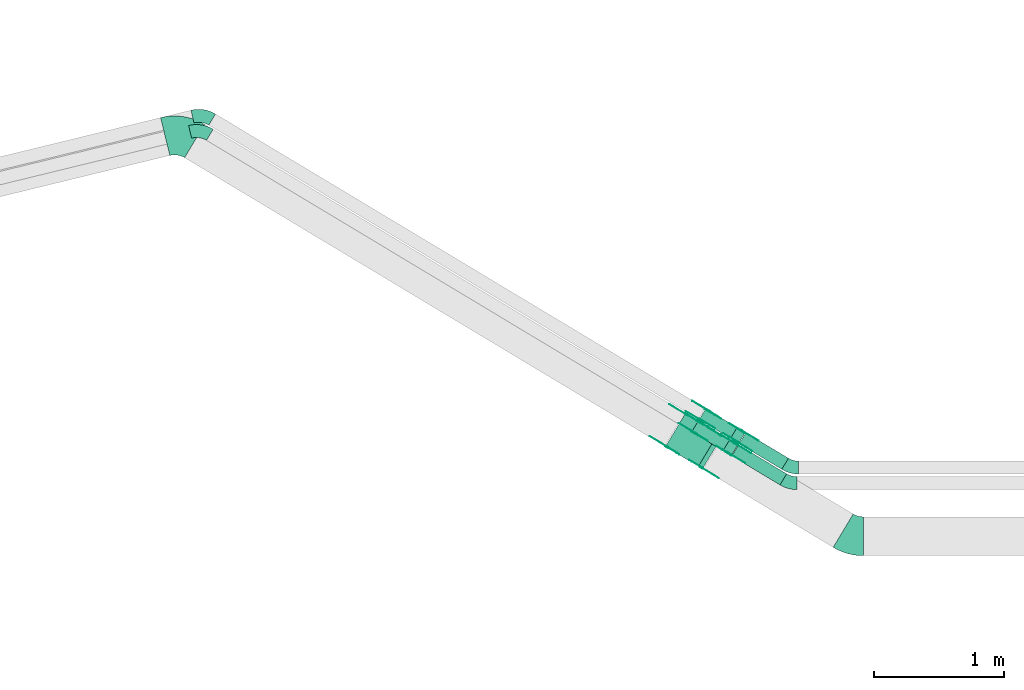
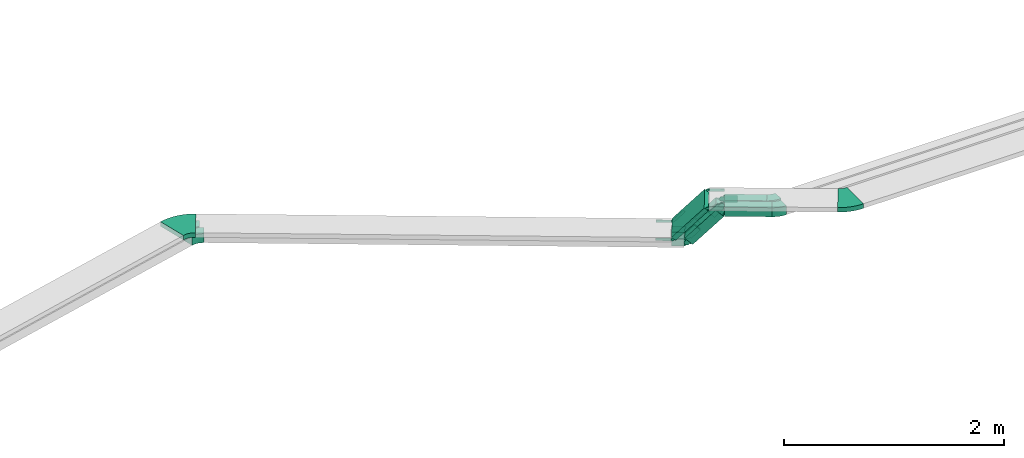
# One storey, part 4 of 27: 30 flow fittings, 5 flow segments.
"""IFC2X3 building model written with IfcOpenShell, lengths in millimetres."""

from ifc_helpers import new_model, entity, si_unit, converted_unit, derived_unit, direction, frame, frame_2d, origin, origin_2d_with_axis, place, context, subcontext, project, spatial, polyline, circle_curve, parameter, trimmed, segment, composite_curve, rectangle, outline, extrude, source, transform, mapped, material, type_object, type_shapes, element, save


model = new_model("IFC2X3")

# Units and contexts
model_context = context("Model", 3, precision=0.01, world=origin(), true_north=direction((6.12303176911189e-17, 1.0)))
body_context = subcontext(model_context, "Body", "Model", "MODEL_VIEW")
ifc_project = project(units=[si_unit("LENGTHUNIT", "METRE", prefix="MILLI"), si_unit("AREAUNIT", "SQUARE_METRE"), si_unit("VOLUMEUNIT", "CUBIC_METRE"), converted_unit("PLANEANGLEUNIT", "DEGREE", entity("IfcRatioMeasure", 0.0174532925199433), si_unit("PLANEANGLEUNIT", "RADIAN"), dimensions=[0, 0, 0, 0, 0, 0, 0]), si_unit("MASSUNIT", "GRAM", prefix="KILO"), derived_unit("MASSDENSITYUNIT", [(si_unit("MASSUNIT", "GRAM", prefix="KILO"), 1), (si_unit("LENGTHUNIT", "METRE"), -3)]), derived_unit("MOMENTOFINERTIAUNIT", [(si_unit("LENGTHUNIT", "METRE"), 4)]), si_unit("TIMEUNIT", "SECOND"), si_unit("FREQUENCYUNIT", "HERTZ"), si_unit("THERMODYNAMICTEMPERATUREUNIT", "DEGREE_CELSIUS"), derived_unit("THERMALTRANSMITTANCEUNIT", [(si_unit("MASSUNIT", "GRAM", prefix="KILO"), 1), (si_unit("THERMODYNAMICTEMPERATUREUNIT", "KELVIN"), -1), (si_unit("TIMEUNIT", "SECOND"), -3)]), derived_unit("VOLUMETRICFLOWRATEUNIT", [(si_unit("LENGTHUNIT", "METRE"), 3), (si_unit("TIMEUNIT", "SECOND"), -1)]), derived_unit("MASSFLOWRATEUNIT", [(si_unit("MASSUNIT", "GRAM", prefix="KILO"), 1), (si_unit("TIMEUNIT", "SECOND"), -1)]), derived_unit("ROTATIONALFREQUENCYUNIT", [(si_unit("TIMEUNIT", "SECOND"), -1)]), si_unit("ELECTRICCURRENTUNIT", "AMPERE"), si_unit("ELECTRICVOLTAGEUNIT", "VOLT"), si_unit("POWERUNIT", "WATT"), si_unit("FORCEUNIT", "NEWTON", prefix="KILO"), si_unit("ILLUMINANCEUNIT", "LUX"), si_unit("LUMINOUSFLUXUNIT", "LUMEN"), si_unit("LUMINOUSINTENSITYUNIT", "CANDELA"), derived_unit("USERDEFINED", [(si_unit("MASSUNIT", "GRAM", prefix="KILO"), -1), (si_unit("LENGTHUNIT", "METRE"), -2), (si_unit("TIMEUNIT", "SECOND"), 3), (si_unit("LUMINOUSFLUXUNIT", "LUMEN"), 1)]), derived_unit("LINEARVELOCITYUNIT", [(si_unit("LENGTHUNIT", "METRE"), 1), (si_unit("TIMEUNIT", "SECOND"), -1)]), si_unit("PRESSUREUNIT", "PASCAL"), derived_unit("USERDEFINED", [(si_unit("LENGTHUNIT", "METRE"), -2), (si_unit("MASSUNIT", "GRAM", prefix="KILO"), 1), (si_unit("TIMEUNIT", "SECOND"), -2)]), derived_unit("LINEARFORCEUNIT", [(si_unit("MASSUNIT", "GRAM", prefix="KILO"), 1), (si_unit("LENGTHUNIT", "METRE"), 1), (si_unit("TIMEUNIT", "SECOND"), -2), (si_unit("LENGTHUNIT", "METRE"), -1)]), derived_unit("PLANARFORCEUNIT", [(si_unit("MASSUNIT", "GRAM", prefix="KILO"), 1), (si_unit("LENGTHUNIT", "METRE"), 1), (si_unit("TIMEUNIT", "SECOND"), -2), (si_unit("LENGTHUNIT", "METRE"), -2)])], contexts=[model_context])

# Site, building, storey
site_placement = place(None, origin())
site = spatial("IfcSite", under=ifc_project, at=site_placement, CompositionType="ELEMENT")
building_placement = place(site_placement, origin())
building = spatial("IfcBuilding", under=site, at=building_placement, CompositionType="ELEMENT")
storey_placement = place(building_placement, origin())
storey = spatial("IfcBuildingStorey", under=building, at=storey_placement, CompositionType="ELEMENT", Elevation=0.0)

# Flow segments
cable_carrier_segment_type = type_object("IfcCableCarrierSegmentType", PredefinedType="CABLETRAYSEGMENT")
flow_segment_1_placement = place(storey_placement, frame((2555.69, 12171.22, 2950.0)))
element("IfcFlowSegment", 1, at=flow_segment_1_placement, inside=storey, type_object=cable_carrier_segment_type, context=body_context, shape_type="SweptSolid", body=[
    extrude(rectangle(XDim=432.962240895032, YDim=99.9999999999993, at=origin_2d_with_axis()), frame((211.31, 154.35, 0.0), z_axis=(0.0, 0.0, 1.0), x_axis=(-0.857167300702077, 0.515038074910114, 0.0)), (0.0, 0.0, 1.0), 99.9999999999994),
])
flow_segment_2_placement = place(storey_placement, frame((2612.35, 12291.22, 2950.0)))
element("IfcFlowSegment", 2, at=flow_segment_2_placement, inside=storey, type_object=cable_carrier_segment_type, context=body_context, shape_type="SweptSolid", body=[
    extrude(rectangle(XDim=383.040500784393, YDim=99.9999999999987, at=origin_2d_with_axis()), frame((189.92, 141.5, 0.0), z_axis=(0.0, 0.0, 1.0), x_axis=(-0.85716730070208, 0.515038074910108, 0.0)), (0.0, 0.0, 1.0), 100.0),
])
flow_segment_3_placement = place(storey_placement, frame((2246.61, 12396.61, 2635.15)))
element("IfcFlowSegment", 3, at=flow_segment_3_placement, inside=storey, type_object=cable_carrier_segment_type, context=body_context, shape_type="SweptSolid", body=[
    extrude(rectangle(XDim=100.000000000001, YDim=99.9999999999976, at=frame_2d((0.0, 0.0), x_axis=(0.0, 1.0))), frame((57.6, 207.05, 33.46), z_axis=(0.57355687566977, -0.344627739362477, 0.743144825477403), x_axis=(-0.515038074910093, -0.857167300702089, 0.0)), (0.0, 0.0, 1.0), 420.88675734891),
])
flow_segment_4_placement = place(storey_placement, frame((2043.9, 12294.88, 2818.61)))
element("IfcFlowSegment", 4, at=flow_segment_4_placement, inside=storey, type_object=cable_carrier_segment_type, context=body_context, shape_type="SweptSolid", body=[
    extrude(rectangle(XDim=50.0000000000007, YDim=300.0, at=frame_2d((0.0, 0.0), x_axis=(0.0, 1.0))), frame((93.18, 290.86, 16.73), z_axis=(0.573556875669757, -0.344627739362442, 0.74314482547743), x_axis=(0.515038074910054, 0.857167300702113, 0.0)), (0.0, 0.0, 1.0), 443.148191614342),
])
flow_segment_5_placement = place(storey_placement, frame((2303.27, 12490.89, 2635.15)))
element("IfcFlowSegment", 5, at=flow_segment_5_placement, inside=storey, type_object=cable_carrier_segment_type, context=body_context, shape_type="SweptSolid", body=[
    extrude(rectangle(XDim=100.0, YDim=99.999999999998, at=frame_2d((0.0, 0.0), x_axis=(0.0, 1.0))), frame((57.6, 207.05, 33.46), z_axis=(0.573556875672807, -0.344627739364302, 0.743144825474213), x_axis=(-0.515038074910098, -0.857167300702086, 0.0)), (0.0, 0.0, 1.0), 420.886757348871),
])

# Flow fittings
ifc_material_1 = material(Name="G")
cable_carrier_fitting_type_1 = type_object("IfcCableCarrierFittingType", PredefinedType="NOTDEFINED", material=ifc_material_1)
shared_shape_1 = source(origin(), body_context, "Body", "SweptSolid", [
    extrude(outline(composite_curve([segment(trimmed(circle_curve(frame_2d((-44.59, 0.0), x_axis=(1.0, 0.0)), 12.5), [parameter(90.0000000000007)], [parameter(270.0)], True, "PARAMETER"), True, "CONTINUOUS"), segment(polyline([(-44.59, -12.5), (-33.09, -12.5)]), True, "CONTINUOUS"), segment(polyline([(-33.09, -12.5), (-31.23, -14.5)]), True, "CONTINUOUS"), segment(polyline([(-31.23, -14.5), (108.91, -14.5)]), True, "CONTINUOUS"), segment(polyline([(108.91, -14.5), (108.91, 14.5)]), True, "CONTINUOUS"), segment(polyline([(108.91, 14.5), (-31.23, 14.5)]), True, "CONTINUOUS"), segment(polyline([(-31.23, 14.5), (-33.09, 12.5)]), True, "CONTINUOUS"), segment(polyline([(-33.09, 12.5), (-44.59, 12.5)]), True, "CONTINUOUS")], self_intersect=False)), frame((44.59, 0.0, 0.0), z_axis=(0.0, 0.0, -1.0), x_axis=(1.0, 0.0, 0.0)), (0.0, 0.0, -1.0), 2.0),
])
type_shapes(cable_carrier_fitting_type_1, [shared_shape_1])
flow_fitting_1_placement = place(storey_placement, frame((2054.18, 12465.85, 2825.0), z_axis=(-0.515038074910058, -0.85716730070211, 0.0), x_axis=(0.57355687566975, -0.344627739362441, 0.743144825477436)))
element("IfcFlowFitting", 6, at=flow_fitting_1_placement, inside=storey, type_object=cable_carrier_fitting_type_1, material=ifc_material_1, context=body_context, shape_type="MappedRepresentation", body=[
    mapped(shared_shape_1, transform((0.0, 0.0, 0.0), scale=1.0)),
])
cable_carrier_fitting_type_2 = type_object("IfcCableCarrierFittingType", PredefinedType="NOTDEFINED", material=ifc_material_1)
type_shapes(cable_carrier_fitting_type_2, [shared_shape_1])
flow_fitting_2_placement = place(storey_placement, frame((2202.99, 12713.51, 2825.0), z_axis=(0.515038074910046, 0.857167300702117, 0.0), x_axis=(-0.857167300702117, 0.515038074910046, 0.0)))
element("IfcFlowFitting", 7, at=flow_fitting_2_placement, inside=storey, type_object=cable_carrier_fitting_type_2, material=ifc_material_1, context=body_context, shape_type="MappedRepresentation", body=[
    mapped(shared_shape_1, transform((0.0, 0.0, 0.0), scale=1.0)),
])
flow_fitting_3_placement = place(storey_placement, frame((2474.15, 12552.91, 3175.0), z_axis=(0.515038074910075, 0.8571673007021, 0.0), x_axis=(0.8571673007021, -0.515038074910075, 0.0)))
element("IfcFlowFitting", 8, at=flow_fitting_3_placement, inside=storey, type_object=cable_carrier_fitting_type_1, material=ifc_material_1, context=body_context, shape_type="MappedRepresentation", body=[
    mapped(shared_shape_1, transform((0.0, 0.0, 0.0), scale=1.0)),
])
flow_fitting_4_placement = place(storey_placement, frame((2325.34, 12305.26, 3175.0), z_axis=(-0.515038074910083, -0.857167300702095, 0.0), x_axis=(-0.57355687566976, 0.344627739362467, -0.743144825477416)))
element("IfcFlowFitting", 9, at=flow_fitting_4_placement, inside=storey, type_object=cable_carrier_fitting_type_2, material=ifc_material_1, context=body_context, shape_type="MappedRepresentation", body=[
    mapped(shared_shape_1, transform((0.0, 0.0, 0.0), scale=1.0)),
])
cable_carrier_fitting_type_3 = type_object("IfcCableCarrierFittingType", PredefinedType="NOTDEFINED", material=ifc_material_1)
shared_shape_2 = source(origin(), body_context, "Body", "SweptSolid", [
    extrude(outline(composite_curve([segment(trimmed(circle_curve(frame_2d((-44.59, 0.0), x_axis=(1.0, 0.0)), 12.5), [parameter(90.0000000000007)], [parameter(270.0)], True, "PARAMETER"), True, "CONTINUOUS"), segment(polyline([(-44.59, -12.5), (-33.09, -12.5)]), True, "CONTINUOUS"), segment(polyline([(-33.09, -12.5), (-31.23, -14.5)]), True, "CONTINUOUS"), segment(polyline([(-31.23, -14.5), (108.91, -14.5)]), True, "CONTINUOUS"), segment(polyline([(108.91, -14.5), (108.91, 14.5)]), True, "CONTINUOUS"), segment(polyline([(108.91, 14.5), (-31.23, 14.5)]), True, "CONTINUOUS"), segment(polyline([(-31.23, 14.5), (-33.09, 12.5)]), True, "CONTINUOUS"), segment(polyline([(-33.09, 12.5), (-44.59, 12.5)]), True, "CONTINUOUS")], self_intersect=False)), frame((44.59, 0.0, 0.0)), (0.0, 0.0, 1.0), 2.0),
])
type_shapes(cable_carrier_fitting_type_3, [shared_shape_2])
flow_fitting_5_placement = place(storey_placement, frame((2204.02, 12715.22, 2825.0), z_axis=(0.515038074910066, 0.857167300702105, 0.0), x_axis=(0.573556875669743, -0.344627739362453, 0.743144825477436)))
element("IfcFlowFitting", 10, at=flow_fitting_5_placement, inside=storey, type_object=cable_carrier_fitting_type_3, material=ifc_material_1, context=body_context, shape_type="MappedRepresentation", body=[
    mapped(shared_shape_2, transform((0.0, 0.0, 0.0), scale=1.0)),
])
cable_carrier_fitting_type_4 = type_object("IfcCableCarrierFittingType", PredefinedType="NOTDEFINED", material=ifc_material_1)
type_shapes(cable_carrier_fitting_type_4, [shared_shape_2])
flow_fitting_6_placement = place(storey_placement, frame((2055.21, 12467.57, 2825.0), z_axis=(-0.51503807491007, -0.857167300702103, 0.0), x_axis=(-0.857167300702103, 0.51503807491007, 0.0)))
element("IfcFlowFitting", 11, at=flow_fitting_6_placement, inside=storey, type_object=cable_carrier_fitting_type_4, material=ifc_material_1, context=body_context, shape_type="MappedRepresentation", body=[
    mapped(shared_shape_2, transform((0.0, 0.0, 0.0), scale=1.0)),
])
flow_fitting_7_placement = place(storey_placement, frame((2324.31, 12303.54, 3175.0), z_axis=(-0.515038074910064, -0.857167300702107, 0.0), x_axis=(0.857167300702107, -0.515038074910064, 0.0)))
element("IfcFlowFitting", 12, at=flow_fitting_7_placement, inside=storey, type_object=cable_carrier_fitting_type_3, material=ifc_material_1, context=body_context, shape_type="MappedRepresentation", body=[
    mapped(shared_shape_2, transform((0.0, 0.0, 0.0), scale=1.0)),
])
flow_fitting_8_placement = place(storey_placement, frame((2473.12, 12551.2, 3175.0), z_axis=(0.515038074910059, 0.85716730070211, 0.0), x_axis=(-0.573556875669774, 0.344627739362443, -0.743144825477416)))
element("IfcFlowFitting", 13, at=flow_fitting_8_placement, inside=storey, type_object=cable_carrier_fitting_type_4, material=ifc_material_1, context=body_context, shape_type="MappedRepresentation", body=[
    mapped(shared_shape_2, transform((0.0, 0.0, 0.0), scale=1.0)),
])
cable_carrier_fitting_type_5 = type_object("IfcCableCarrierFittingType", PredefinedType="NOTDEFINED", material=ifc_material_1)
shared_shape_3 = source(origin(), body_context, "Body", "SweptSolid", [
    extrude(outline(composite_curve([segment(trimmed(circle_curve(frame_2d((-41.47, 0.0), x_axis=(1.0, 0.0)), 25.0), [parameter(90.0000000000007)], [parameter(270.0)], True, "PARAMETER"), True, "CONTINUOUS"), segment(polyline([(-41.47, -25.0), (-29.97, -25.0)]), True, "CONTINUOUS"), segment(polyline([(-29.97, -25.0), (-28.1, -38.5)]), True, "CONTINUOUS"), segment(polyline([(-28.1, -38.5), (99.53, -38.5)]), True, "CONTINUOUS"), segment(polyline([(99.53, -38.5), (99.53, 38.5)]), True, "CONTINUOUS"), segment(polyline([(99.53, 38.5), (-28.1, 38.5)]), True, "CONTINUOUS"), segment(polyline([(-28.1, 38.5), (-29.97, 25.0)]), True, "CONTINUOUS"), segment(polyline([(-29.97, 25.0), (-41.47, 25.0)]), True, "CONTINUOUS")], self_intersect=False)), frame((41.47, 0.0, 0.0), z_axis=(0.0, 0.0, -1.0), x_axis=(1.0, 0.0, 0.0)), (0.0, 0.0, -1.0), 2.0),
])
type_shapes(cable_carrier_fitting_type_5, [shared_shape_3])
flow_fitting_9_placement = place(storey_placement, frame((2536.57, 12411.0, 3000.0), z_axis=(-0.515038074910089, -0.857167300702091, 0.0), x_axis=(-0.573556875669768, 0.344627739362478, -0.743144825477405)))
element("IfcFlowFitting", 14, at=flow_fitting_9_placement, inside=storey, type_object=cable_carrier_fitting_type_5, material=ifc_material_1, context=body_context, shape_type="MappedRepresentation", body=[
    mapped(shared_shape_3, transform((0.0, 0.0, 0.0), scale=1.0)),
])
cable_carrier_fitting_type_6 = type_object("IfcCableCarrierFittingType", PredefinedType="NOTDEFINED", material=ifc_material_1)
type_shapes(cable_carrier_fitting_type_6, [shared_shape_3])
flow_fitting_10_placement = place(storey_placement, frame((2582.36, 12487.22, 3000.0), z_axis=(0.5150380749101, 0.857167300702084, 0.0), x_axis=(0.857167300702084, -0.5150380749101, 0.0)))
element("IfcFlowFitting", 15, at=flow_fitting_10_placement, inside=storey, type_object=cable_carrier_fitting_type_6, material=ifc_material_1, context=body_context, shape_type="MappedRepresentation", body=[
    mapped(shared_shape_3, transform((0.0, 0.0, 0.0), scale=1.0)),
])
flow_fitting_11_placement = place(storey_placement, frame((2266.44, 12573.31, 2650.0), z_axis=(-0.515038074910057, -0.857167300702111, 0.0), x_axis=(0.57355687566977, -0.344627739362475, 0.743144825477405)))
element("IfcFlowFitting", 16, at=flow_fitting_11_placement, inside=storey, type_object=cable_carrier_fitting_type_5, material=ifc_material_1, context=body_context, shape_type="MappedRepresentation", body=[
    mapped(shared_shape_3, transform((0.0, 0.0, 0.0), scale=1.0)),
])
flow_fitting_12_placement = place(storey_placement, frame((2312.24, 12649.53, 2650.0), z_axis=(0.515038074910046, 0.857167300702118, 0.0), x_axis=(-0.857167300702118, 0.515038074910046, 0.0)))
element("IfcFlowFitting", 17, at=flow_fitting_12_placement, inside=storey, type_object=cable_carrier_fitting_type_6, material=ifc_material_1, context=body_context, shape_type="MappedRepresentation", body=[
    mapped(shared_shape_3, transform((0.0, 0.0, 0.0), scale=1.0)),
])
flow_fitting_13_placement = place(storey_placement, frame((2640.05, 12583.23, 3000.0), z_axis=(0.5150380749101, 0.857167300702085, 0.0), x_axis=(0.857167300702085, -0.5150380749101, 0.0)))
element("IfcFlowFitting", 18, at=flow_fitting_13_placement, inside=storey, type_object=cable_carrier_fitting_type_5, material=ifc_material_1, context=body_context, shape_type="MappedRepresentation", body=[
    mapped(shared_shape_3, transform((0.0, 0.0, 0.0), scale=1.0)),
])
flow_fitting_14_placement = place(storey_placement, frame((2594.25, 12507.01, 3000.0), z_axis=(-0.515038074910108, -0.85716730070208, 0.0), x_axis=(-0.573556875669665, 0.344627739362432, -0.743144825477505)))
element("IfcFlowFitting", 19, at=flow_fitting_14_placement, inside=storey, type_object=cable_carrier_fitting_type_6, material=ifc_material_1, context=body_context, shape_type="MappedRepresentation", body=[
    mapped(shared_shape_3, transform((0.0, 0.0, 0.0), scale=1.0)),
])
flow_fitting_15_placement = place(storey_placement, frame((2369.92, 12745.54, 2650.0), z_axis=(0.515038074910055, 0.857167300702112, 0.0), x_axis=(-0.857167300702112, 0.515038074910055, 0.0)))
element("IfcFlowFitting", 20, at=flow_fitting_15_placement, inside=storey, type_object=cable_carrier_fitting_type_5, material=ifc_material_1, context=body_context, shape_type="MappedRepresentation", body=[
    mapped(shared_shape_3, transform((0.0, 0.0, 0.0), scale=1.0)),
])
flow_fitting_16_placement = place(storey_placement, frame((2324.12, 12669.32, 2650.0), z_axis=(-0.515038074910047, -0.857167300702117, 0.0), x_axis=(0.573556875669679, -0.344627739362409, 0.743144825477505)))
element("IfcFlowFitting", 21, at=flow_fitting_16_placement, inside=storey, type_object=cable_carrier_fitting_type_6, material=ifc_material_1, context=body_context, shape_type="MappedRepresentation", body=[
    mapped(shared_shape_3, transform((0.0, 0.0, 0.0), scale=1.0)),
])
cable_carrier_fitting_type_7 = type_object("IfcCableCarrierFittingType", PredefinedType="NOTDEFINED", material=ifc_material_1)
shared_shape_4 = source(origin(), body_context, "Body", "SweptSolid", [
    extrude(outline(composite_curve([segment(trimmed(circle_curve(frame_2d((-41.47, 0.0), x_axis=(1.0, 0.0)), 25.0), [parameter(90.0000000000007)], [parameter(270.0)], True, "PARAMETER"), True, "CONTINUOUS"), segment(polyline([(-41.47, -25.0), (-29.97, -25.0)]), True, "CONTINUOUS"), segment(polyline([(-29.97, -25.0), (-28.1, -38.5)]), True, "CONTINUOUS"), segment(polyline([(-28.1, -38.5), (99.53, -38.5)]), True, "CONTINUOUS"), segment(polyline([(99.53, -38.5), (99.53, 38.5)]), True, "CONTINUOUS"), segment(polyline([(99.53, 38.5), (-28.1, 38.5)]), True, "CONTINUOUS"), segment(polyline([(-28.1, 38.5), (-29.97, 25.0)]), True, "CONTINUOUS"), segment(polyline([(-29.97, 25.0), (-41.47, 25.0)]), True, "CONTINUOUS")], self_intersect=False)), frame((41.47, 0.0, 0.0)), (0.0, 0.0, 1.0), 2.0),
])
type_shapes(cable_carrier_fitting_type_7, [shared_shape_4])
flow_fitting_17_placement = place(storey_placement, frame((2583.39, 12488.94, 3000.0), z_axis=(0.515038074910081, 0.857167300702096, 0.0), x_axis=(-0.573556875669775, 0.344627739362466, -0.743144825477405)))
element("IfcFlowFitting", 22, at=flow_fitting_17_placement, inside=storey, type_object=cable_carrier_fitting_type_7, material=ifc_material_1, context=body_context, shape_type="MappedRepresentation", body=[
    mapped(shared_shape_4, transform((0.0, 0.0, 0.0), scale=1.0)),
])
cable_carrier_fitting_type_8 = type_object("IfcCableCarrierFittingType", PredefinedType="NOTDEFINED", material=ifc_material_1)
type_shapes(cable_carrier_fitting_type_8, [shared_shape_4])
flow_fitting_18_placement = place(storey_placement, frame((2537.6, 12412.72, 3000.0), z_axis=(-0.515038074910077, -0.857167300702098, 0.0), x_axis=(0.857167300702098, -0.515038074910077, 0.0)))
element("IfcFlowFitting", 23, at=flow_fitting_18_placement, inside=storey, type_object=cable_carrier_fitting_type_8, material=ifc_material_1, context=body_context, shape_type="MappedRepresentation", body=[
    mapped(shared_shape_4, transform((0.0, 0.0, 0.0), scale=1.0)),
])
flow_fitting_19_placement = place(storey_placement, frame((2313.27, 12651.25, 2650.0), z_axis=(0.515038074910065, 0.857167300702106, 0.0), x_axis=(0.573556875669763, -0.344627739362486, 0.743144825477405)))
element("IfcFlowFitting", 24, at=flow_fitting_19_placement, inside=storey, type_object=cable_carrier_fitting_type_7, material=ifc_material_1, context=body_context, shape_type="MappedRepresentation", body=[
    mapped(shared_shape_4, transform((0.0, 0.0, 0.0), scale=1.0)),
])
flow_fitting_20_placement = place(storey_placement, frame((2267.47, 12575.03, 2650.0), z_axis=(-0.515038074910069, -0.857167300702104, 0.0), x_axis=(-0.857167300702104, 0.515038074910069, 0.0)))
element("IfcFlowFitting", 25, at=flow_fitting_20_placement, inside=storey, type_object=cable_carrier_fitting_type_8, material=ifc_material_1, context=body_context, shape_type="MappedRepresentation", body=[
    mapped(shared_shape_4, transform((0.0, 0.0, 0.0), scale=1.0)),
])
flow_fitting_21_placement = place(storey_placement, frame((2593.22, 12505.29, 3000.0), z_axis=(-0.515038074910088, -0.857167300702092, 0.0), x_axis=(0.857167300702092, -0.515038074910088, 0.0)))
element("IfcFlowFitting", 26, at=flow_fitting_21_placement, inside=storey, type_object=cable_carrier_fitting_type_7, material=ifc_material_1, context=body_context, shape_type="MappedRepresentation", body=[
    mapped(shared_shape_4, transform((0.0, 0.0, 0.0), scale=1.0)),
])
flow_fitting_22_placement = place(storey_placement, frame((2639.02, 12581.51, 3000.0), z_axis=(0.515038074910083, 0.857167300702095, 0.0), x_axis=(-0.573556875669679, 0.344627739362409, -0.743144825477505)))
element("IfcFlowFitting", 27, at=flow_fitting_22_placement, inside=storey, type_object=cable_carrier_fitting_type_8, material=ifc_material_1, context=body_context, shape_type="MappedRepresentation", body=[
    mapped(shared_shape_4, transform((0.0, 0.0, 0.0), scale=1.0)),
])
flow_fitting_23_placement = place(storey_placement, frame((2323.09, 12667.6, 2650.0), z_axis=(-0.515038074910067, -0.857167300702105, 0.0), x_axis=(-0.857167300702105, 0.515038074910067, 0.0)))
element("IfcFlowFitting", 28, at=flow_fitting_23_placement, inside=storey, type_object=cable_carrier_fitting_type_7, material=ifc_material_1, context=body_context, shape_type="MappedRepresentation", body=[
    mapped(shared_shape_4, transform((0.0, 0.0, 0.0), scale=1.0)),
])
flow_fitting_24_placement = place(storey_placement, frame((2368.89, 12743.82, 2650.0), z_axis=(0.515038074910072, 0.857167300702102, 0.0), x_axis=(0.573556875669665, -0.344627739362432, 0.743144825477505)))
element("IfcFlowFitting", 29, at=flow_fitting_24_placement, inside=storey, type_object=cable_carrier_fitting_type_8, material=ifc_material_1, context=body_context, shape_type="MappedRepresentation", body=[
    mapped(shared_shape_4, transform((0.0, 0.0, 0.0), scale=1.0)),
])
ifc_material_2 = material()
cable_carrier_fitting_type_9 = type_object("IfcCableCarrierFittingType", Name="470_DKC_S5_Variable Angle Elbow 0-45:-", PredefinedType="NOTDEFINED", material=ifc_material_2)
shared_shape_5 = source(origin(), body_context, "Body", "SweptSolid", [
    extrude(outline(composite_curve([segment(polyline([(-52.47, -64.41), (-51.47, -64.41)]), True, "CONTINUOUS"), segment(trimmed(circle_curve(frame_2d((-51.47, 185.59), x_axis=(0.0, -1.0)), 250.0), [parameter(0.0)], [parameter(31.0000000000001)], True, "PARAMETER"), True, "CONTINUOUS"), segment(polyline([(77.29, -28.7), (78.15, -28.19)]), True, "CONTINUOUS"), segment(polyline([(78.15, -28.19), (26.64, 57.53)]), True, "CONTINUOUS"), segment(polyline([(26.64, 57.53), (25.79, 57.01)]), True, "CONTINUOUS"), segment(trimmed(circle_curve(frame_2d((-51.47, 185.59), x_axis=(0.0, -1.0)), 150.0), [parameter(0.0)], [parameter(31.0000000000001)], True, "PARAMETER"), False, "CONTINUOUS"), segment(polyline([(-51.47, 35.59), (-52.47, 35.59)]), True, "CONTINUOUS"), segment(polyline([(-52.47, 35.59), (-52.47, -64.41)]), True, "CONTINUOUS")], self_intersect=False)), frame((-4.0, 14.41, -50.0)), (0.0, 0.0, 1.0), 100.0),
])
type_shapes(cable_carrier_fitting_type_9, [shared_shape_5])
for number, where, z_axis, x_axis, name in (
    (30, (3000.97, 12185.0, 3000.0), (0.0, 0.0, 1.0), (0.85716730070211, -0.515038074910058, 0.0), "470_DKC_S5_Variable Angle Elbow 0-45:-"),
    (31, (3014.83, 12305.0, 3000.0), (0.0, 0.0, 1.0), (0.857167300702094, -0.515038074910084, 0.0), "470_DKC_S5_Variable Angle Elbow 0-45:-"),
):
    element("IfcFlowFitting", number, at=place(storey_placement, frame(where, z_axis=z_axis, x_axis=x_axis)), inside=storey, type_object=cable_carrier_fitting_type_9, material=ifc_material_2, Name=name, ObjectType="470_DKC_S5_Variable Angle Elbow 0-45:-", context=body_context, shape_type="MappedRepresentation", body=[
        mapped(shared_shape_5, transform((0.0, 0.0, 0.0), scale=1.0)),
    ])
cable_carrier_fitting_type_10 = type_object("IfcCableCarrierFittingType", Name="470_DKC_S5_Variable Angle Elbow 0-45:-", PredefinedType="NOTDEFINED", material=ifc_material_2)
shared_shape_6 = source(origin(), body_context, "Body", "SweptSolid", [
    extrude(outline(composite_curve([segment(polyline([(-71.27, -79.09), (-70.27, -79.09)]), True, "CONTINUOUS"), segment(trimmed(circle_curve(frame_2d((-70.27, 170.91), x_axis=(0.0, -1.0)), 250.0), [parameter(0.0)], [parameter(44.6989733065183)], True, "PARAMETER"), True, "CONTINUOUS"), segment(polyline([(105.58, -6.8), (106.29, -6.09)]), True, "CONTINUOUS"), segment(polyline([(106.29, -6.09), (35.95, 64.99)]), True, "CONTINUOUS"), segment(polyline([(35.95, 64.99), (35.24, 64.28)]), True, "CONTINUOUS"), segment(trimmed(circle_curve(frame_2d((-70.27, 170.91), x_axis=(0.0, -1.0)), 150.0), [parameter(0.0)], [parameter(44.6989733065183)], True, "PARAMETER"), False, "CONTINUOUS"), segment(polyline([(-70.27, 20.91), (-71.27, 20.91)]), True, "CONTINUOUS"), segment(polyline([(-71.27, 20.91), (-71.27, -79.09)]), True, "CONTINUOUS")], self_intersect=False)), frame((-11.96, 29.09, -50.0)), (0.0, 0.0, 1.0), 100.0),
])
type_shapes(cable_carrier_fitting_type_10, [shared_shape_6])
for number, where, z_axis, x_axis, name in (
    (32, (-1539.65, 14913.28, 2650.0), (0.0, 0.0, 1.0), (-0.857167300702109, 0.51503807491006, 0.0), "470_DKC_S5_Variable Angle Elbow 0-45:-"),
    (33, (-1521.76, 15030.86, 2650.0), (0.0, 0.0, 1.0), (-0.857167300702113, 0.515038074910054, 0.0), "470_DKC_S5_Variable Angle Elbow 0-45:-"),
):
    element("IfcFlowFitting", number, at=place(storey_placement, frame(where, z_axis=z_axis, x_axis=x_axis)), inside=storey, type_object=cable_carrier_fitting_type_10, material=ifc_material_2, Name=name, ObjectType="470_DKC_S5_Variable Angle Elbow 0-45:-", context=body_context, shape_type="MappedRepresentation", body=[
        mapped(shared_shape_6, transform((0.0, 0.0, 0.0), scale=1.0)),
    ])
cable_carrier_fitting_type_11 = type_object("IfcCableCarrierFittingType", Name="470_DKC_S5_Variable Angle Elbow 0-45:-", PredefinedType="NOTDEFINED", material=ifc_material_2)
shared_shape_7 = source(origin(), body_context, "Body", "SweptSolid", [
    extrude(outline(composite_curve([segment(polyline([(-78.22, -171.55), (-77.22, -171.55)]), True, "CONTINUOUS"), segment(trimmed(circle_curve(frame_2d((-77.22, 278.45), x_axis=(0.0, -1.0)), 450.0), [parameter(0.0)], [parameter(31.0000000000002)], True, "PARAMETER"), True, "CONTINUOUS"), segment(polyline([(154.55, -107.28), (155.4, -106.76)]), True, "CONTINUOUS"), segment(polyline([(155.4, -106.76), (0.89, 150.39)]), True, "CONTINUOUS"), segment(polyline([(0.89, 150.39), (0.04, 149.87)]), True, "CONTINUOUS"), segment(trimmed(circle_curve(frame_2d((-77.22, 278.45), x_axis=(0.0, -1.0)), 150.0), [parameter(0.0)], [parameter(31.0000000000002)], True, "PARAMETER"), False, "CONTINUOUS"), segment(polyline([(-77.22, 128.45), (-78.22, 128.45)]), True, "CONTINUOUS"), segment(polyline([(-78.22, 128.45), (-78.22, -171.55)]), True, "CONTINUOUS")], self_intersect=False)), frame((-5.98, 21.55, -25.0)), (0.0, 0.0, 1.0), 49.9999999999988),
])
type_shapes(cable_carrier_fitting_type_11, [shared_shape_7])
flow_fitting_25_placement = place(storey_placement, frame((3485.93, 11775.27, 3175.0), z_axis=(0.0, 0.0, 1.0), x_axis=(0.857167300702103, -0.515038074910069, 0.0)))
element("IfcFlowFitting", 34, at=flow_fitting_25_placement, inside=storey, type_object=cable_carrier_fitting_type_11, material=ifc_material_2, Name="470_DKC_S5_Variable Angle Elbow 0-45:-", ObjectType="470_DKC_S5_Variable Angle Elbow 0-45:-", context=body_context, shape_type="MappedRepresentation", body=[
    mapped(shared_shape_7, transform((0.0, 0.0, 0.0), scale=1.0)),
])
cable_carrier_fitting_type_12 = type_object("IfcCableCarrierFittingType", Name="470_DKC_S5_Variable Angle Elbow 0-45:-", PredefinedType="NOTDEFINED", material=ifc_material_2)
shared_shape_8 = source(origin(), body_context, "Body", "SweptSolid", [
    extrude(outline(composite_curve([segment(polyline([(-106.43, -193.55), (-105.43, -193.55)]), True, "CONTINUOUS"), segment(trimmed(circle_curve(frame_2d((-105.43, 256.45), x_axis=(0.0, -1.0)), 450.0), [parameter(0.0)], [parameter(44.6989733065181)], True, "PARAMETER"), True, "CONTINUOUS"), segment(polyline([(211.09, -63.42), (211.8, -62.72)]), True, "CONTINUOUS"), segment(polyline([(211.8, -62.72), (0.78, 150.53)]), True, "CONTINUOUS"), segment(polyline([(0.78, 150.53), (0.07, 149.82)]), True, "CONTINUOUS"), segment(trimmed(circle_curve(frame_2d((-105.43, 256.45), x_axis=(0.0, -1.0)), 150.0), [parameter(0.0)], [parameter(44.6989733065181)], True, "PARAMETER"), False, "CONTINUOUS"), segment(polyline([(-105.43, 106.45), (-106.43, 106.45)]), True, "CONTINUOUS"), segment(polyline([(-106.43, 106.45), (-106.43, -193.55)]), True, "CONTINUOUS")], self_intersect=False)), frame((-17.91, 43.55, -25.0)), (0.0, 0.0, 1.0), 49.9999999999983),
])
type_shapes(cable_carrier_fitting_type_12, [shared_shape_8])
flow_fitting_26_placement = place(storey_placement, frame((-1691.94, 14886.45, 2825.0), z_axis=(0.0, 0.0, 1.0), x_axis=(-0.857167300702109, 0.515038074910059, 0.0)))
element("IfcFlowFitting", 35, at=flow_fitting_26_placement, inside=storey, type_object=cable_carrier_fitting_type_12, material=ifc_material_2, Name="470_DKC_S5_Variable Angle Elbow 0-45:-", ObjectType="470_DKC_S5_Variable Angle Elbow 0-45:-", context=body_context, shape_type="MappedRepresentation", body=[
    mapped(shared_shape_8, transform((0.0, 0.0, 0.0), scale=1.0)),
])

save(model, "model.ifc")
